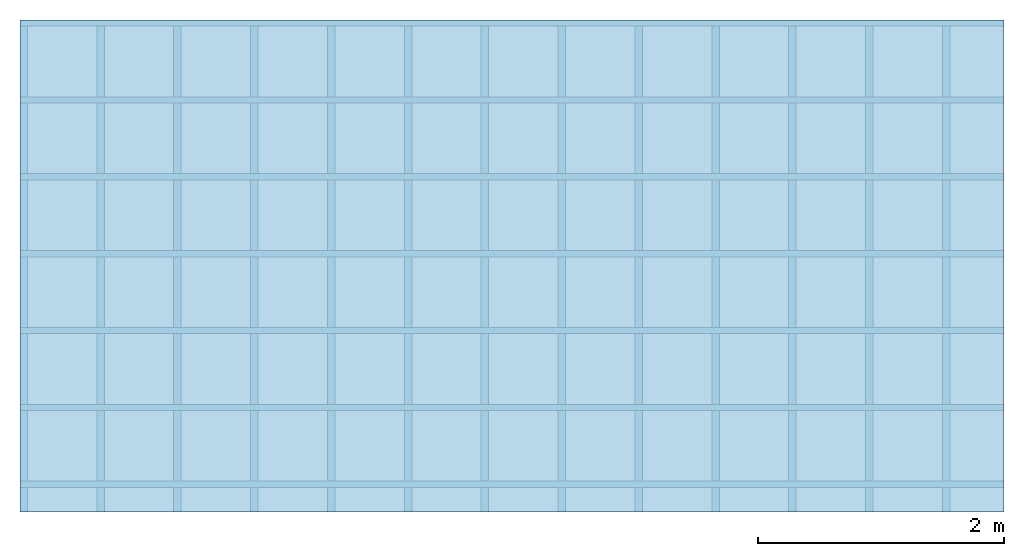
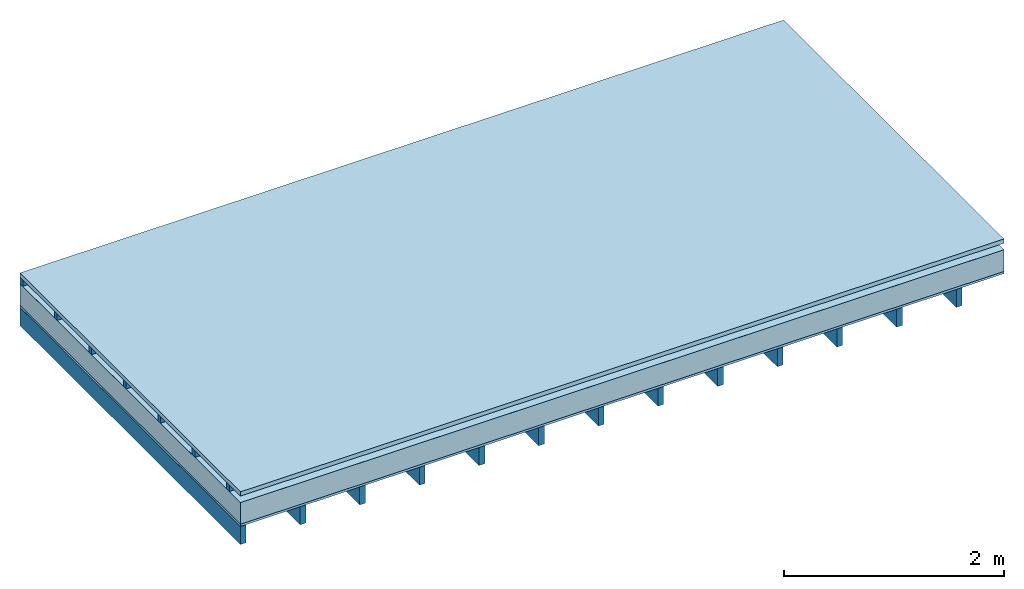
# One storey: 4 plates, 2 members, 1 element without a shape of its own.
"""IFC4 building model written with IfcOpenShell, lengths in metres."""

from ifc_helpers import new_model, si_unit, derived_unit, direction, frame, frame_2d, origin, origin_with_axes, place, context, project, spatial, rectangle, extrude, material, layer, layer_set, type_object, element, aggregate, save


model = new_model("IFC4")

# Units and contexts
plan_context = context("Plan", 3, precision=1e-05, world=origin(), true_north=direction((0.0, 1.0)))
model_context = context("Model", 3, precision=1e-05, world=origin(), true_north=direction((0.0, 1.0)))
ifc_project = project(units=[si_unit("LENGTHUNIT", "METRE"), derived_unit("SOUNDPRESSUREUNIT", [(si_unit("PRESSUREUNIT", "PASCAL", prefix="MICRO"), 0)]), si_unit("ENERGYUNIT", "JOULE", prefix="MEGA"), si_unit("MASSUNIT", "GRAM", prefix="KILO"), derived_unit("THERMALTRANSMITTANCEUNIT", [(si_unit("POWERUNIT", "WATT"), 1), (si_unit("AREAUNIT", "SQUARE_METRE"), -1), (si_unit("THERMODYNAMICTEMPERATUREUNIT", "KELVIN"), -1)]), derived_unit("AREADENSITYUNIT", [(si_unit("MASSUNIT", "GRAM", prefix="KILO"), 1), (si_unit("AREAUNIT", "SQUARE_METRE"), -1)]), derived_unit("USERDEFINED", [(si_unit("ENERGYUNIT", "JOULE", prefix="MEGA"), 1), (si_unit("AREAUNIT", "SQUARE_METRE"), -1)])], contexts=[plan_context, model_context])

# Site, building, storey
site = spatial("IfcSite", under=ifc_project)
building_placement = place(None, origin())
building = spatial("IfcBuilding", under=site, at=building_placement)
storey_placement = place(building_placement, origin())
storey = spatial("IfcBuildingStorey", under=building, at=storey_placement)

# Slab, members, plates
ifc_material_1 = material(Name="Roof tiles", Category="03.015")
ifc_layer_1 = layer(ifc_material_1, 0.047, Name="Roofing")
ifc_layer_2 = layer(None, 0.072, Name="Battens / profiles")
ifc_material_2 = material(Name="Roofing underlay", Category="09.008")
ifc_layer_3 = layer(ifc_material_2, 0.00018, Name="Under the roof")
ifc_material_3 = material(Category="10.009")
ifc_layer_4 = layer(ifc_material_3, 0.24, Name="Exterior insulation layer 1")
ifc_material_4 = material(Category="07.001")
ifc_layer_5 = layer(ifc_material_4, 0.025, Name="Sub-floor")
ifc_material_5 = material(Name="of the art")
ifc_layer_6 = layer(ifc_material_5, 0.0, Name="Bond")
ifc_layer_7 = layer(None, 0.2, Name="Supporting structure")
ifc_layer_set = layer_set([ifc_layer_1, ifc_layer_2, ifc_layer_3, ifc_layer_4, ifc_layer_5, ifc_layer_6, ifc_layer_7])
slab_type = type_object("IfcSlabType", Name="E0057", PredefinedType="NOTDEFINED", material=ifc_layer_set)
slab_placement = place(None, frame((0.0, 0.0, 0.0), z_axis=(0.0, 0.0, -1.0), x_axis=(1.0, 0.0, 0.0)))
slab = element("IfcSlab", 1, at=slab_placement, inside=storey, type_object=slab_type, material=ifc_layer_set, Name="Slab #1")
ifc_material_6 = material()
member_1_placement = place(slab_placement, origin())
member_1 = element("IfcMember", 2, at=member_1_placement, material=ifc_material_6, Name="Battens / profiles", context=plan_context, shape_type="SweptSolid", body=[
    extrude(rectangle(XDim=0.05, YDim=0.072, at=frame_2d((0.025, 0.036), x_axis=(1.0, 0.0))), frame((0.0, 0.0, 0.047), z_axis=(1.0, 0.0, 0.0), x_axis=(0.0, 1.0, 0.0)), (0.0, 0.0, 1.0), 8.0),
    extrude(rectangle(XDim=0.05, YDim=0.072, at=frame_2d((0.025, 0.036), x_axis=(1.0, 0.0))), frame((0.0, 0.625, 0.047), z_axis=(1.0, 0.0, 0.0), x_axis=(0.0, 1.0, 0.0)), (0.0, 0.0, 1.0), 8.0),
    extrude(rectangle(XDim=0.05, YDim=0.072, at=frame_2d((0.025, 0.036), x_axis=(1.0, 0.0))), frame((0.0, 1.25, 0.047), z_axis=(1.0, 0.0, 0.0), x_axis=(0.0, 1.0, 0.0)), (0.0, 0.0, 1.0), 8.0),
    extrude(rectangle(XDim=0.05, YDim=0.072, at=frame_2d((0.025, 0.036), x_axis=(1.0, 0.0))), frame((0.0, 1.875, 0.047), z_axis=(1.0, 0.0, 0.0), x_axis=(0.0, 1.0, 0.0)), (0.0, 0.0, 1.0), 8.0),
    extrude(rectangle(XDim=0.05, YDim=0.072, at=frame_2d((0.025, 0.036), x_axis=(1.0, 0.0))), frame((0.0, 2.5, 0.047), z_axis=(1.0, 0.0, 0.0), x_axis=(0.0, 1.0, 0.0)), (0.0, 0.0, 1.0), 8.0),
    extrude(rectangle(XDim=0.05, YDim=0.072, at=frame_2d((0.025, 0.036), x_axis=(1.0, 0.0))), frame((0.0, 3.125, 0.047), z_axis=(1.0, 0.0, 0.0), x_axis=(0.0, 1.0, 0.0)), (0.0, 0.0, 1.0), 8.0),
    extrude(rectangle(XDim=0.05, YDim=0.072, at=frame_2d((0.025, 0.036), x_axis=(1.0, 0.0))), frame((0.0, 3.75, 0.047), z_axis=(1.0, 0.0, 0.0), x_axis=(0.0, 1.0, 0.0)), (0.0, 0.0, 1.0), 8.0),
])
ifc_material_7 = material()
member_2_placement = place(slab_placement, origin())
member_2 = element("IfcMember", 3, at=member_2_placement, material=ifc_material_7, Name="Supporting structure", context=plan_context, shape_type="SweptSolid", body=[
    extrude(rectangle(XDim=0.06, YDim=0.2, at=frame_2d((0.03, 0.1), x_axis=(1.0, 0.0))), frame((0.0, 4.0, 0.38418), z_axis=(0.0, -1.0, 0.0), x_axis=(1.0, 0.0, 0.0)), (0.0, 0.0, 1.0), 4.0),
    extrude(rectangle(XDim=0.06, YDim=0.2, at=frame_2d((0.03, 0.1), x_axis=(1.0, 0.0))), frame((0.625, 4.0, 0.38418), z_axis=(0.0, -1.0, 0.0), x_axis=(1.0, 0.0, 0.0)), (0.0, 0.0, 1.0), 4.0),
    extrude(rectangle(XDim=0.06, YDim=0.2, at=frame_2d((0.03, 0.1), x_axis=(1.0, 0.0))), frame((1.25, 4.0, 0.38418), z_axis=(0.0, -1.0, 0.0), x_axis=(1.0, 0.0, 0.0)), (0.0, 0.0, 1.0), 4.0),
    extrude(rectangle(XDim=0.06, YDim=0.2, at=frame_2d((0.03, 0.1), x_axis=(1.0, 0.0))), frame((1.875, 4.0, 0.38418), z_axis=(0.0, -1.0, 0.0), x_axis=(1.0, 0.0, 0.0)), (0.0, 0.0, 1.0), 4.0),
    extrude(rectangle(XDim=0.06, YDim=0.2, at=frame_2d((0.03, 0.1), x_axis=(1.0, 0.0))), frame((2.5, 4.0, 0.38418), z_axis=(0.0, -1.0, 0.0), x_axis=(1.0, 0.0, 0.0)), (0.0, 0.0, 1.0), 4.0),
    extrude(rectangle(XDim=0.06, YDim=0.2, at=frame_2d((0.03, 0.1), x_axis=(1.0, 0.0))), frame((3.125, 4.0, 0.38418), z_axis=(0.0, -1.0, 0.0), x_axis=(1.0, 0.0, 0.0)), (0.0, 0.0, 1.0), 4.0),
    extrude(rectangle(XDim=0.06, YDim=0.2, at=frame_2d((0.03, 0.1), x_axis=(1.0, 0.0))), frame((3.75, 4.0, 0.38418), z_axis=(0.0, -1.0, 0.0), x_axis=(1.0, 0.0, 0.0)), (0.0, 0.0, 1.0), 4.0),
    extrude(rectangle(XDim=0.06, YDim=0.2, at=frame_2d((0.03, 0.1), x_axis=(1.0, 0.0))), frame((4.375, 4.0, 0.38418), z_axis=(0.0, -1.0, 0.0), x_axis=(1.0, 0.0, 0.0)), (0.0, 0.0, 1.0), 4.0),
    extrude(rectangle(XDim=0.06, YDim=0.2, at=frame_2d((0.03, 0.1), x_axis=(1.0, 0.0))), frame((5.0, 4.0, 0.38418), z_axis=(0.0, -1.0, 0.0), x_axis=(1.0, 0.0, 0.0)), (0.0, 0.0, 1.0), 4.0),
    extrude(rectangle(XDim=0.06, YDim=0.2, at=frame_2d((0.03, 0.1), x_axis=(1.0, 0.0))), frame((5.625, 4.0, 0.38418), z_axis=(0.0, -1.0, 0.0), x_axis=(1.0, 0.0, 0.0)), (0.0, 0.0, 1.0), 4.0),
    extrude(rectangle(XDim=0.06, YDim=0.2, at=frame_2d((0.03, 0.1), x_axis=(1.0, 0.0))), frame((6.25, 4.0, 0.38418), z_axis=(0.0, -1.0, 0.0), x_axis=(1.0, 0.0, 0.0)), (0.0, 0.0, 1.0), 4.0),
    extrude(rectangle(XDim=0.06, YDim=0.2, at=frame_2d((0.03, 0.1), x_axis=(1.0, 0.0))), frame((6.875, 4.0, 0.38418), z_axis=(0.0, -1.0, 0.0), x_axis=(1.0, 0.0, 0.0)), (0.0, 0.0, 1.0), 4.0),
    extrude(rectangle(XDim=0.06, YDim=0.2, at=frame_2d((0.03, 0.1), x_axis=(1.0, 0.0))), frame((7.5, 4.0, 0.38418), z_axis=(0.0, -1.0, 0.0), x_axis=(1.0, 0.0, 0.0)), (0.0, 0.0, 1.0), 4.0),
])
plate_1_placement = place(slab_placement, origin())
plate_1 = element("IfcPlate", 4, at=plate_1_placement, material=ifc_material_1, Name="Roofing", context=plan_context, shape_type="SweptSolid", body=[
    extrude(rectangle(XDim=8.0, YDim=4.0, at=frame_2d((4.0, 2.0), x_axis=(1.0, 0.0))), origin_with_axes(), (0.0, 0.0, 1.0), 0.047),
])
plate_2_placement = place(slab_placement, origin())
plate_2 = element("IfcPlate", 5, at=plate_2_placement, material=ifc_material_2, Name="Under the roof", context=plan_context, shape_type="SweptSolid", body=[
    extrude(rectangle(XDim=8.0, YDim=4.0, at=frame_2d((4.0, 2.0), x_axis=(1.0, 0.0))), frame((0.0, 0.0, 0.119), z_axis=(0.0, 0.0, 1.0), x_axis=(1.0, 0.0, 0.0)), (0.0, 0.0, 1.0), 0.00018),
])
plate_3_placement = place(slab_placement, origin())
plate_3 = element("IfcPlate", 6, at=plate_3_placement, material=ifc_material_3, Name="Exterior insulation layer 1", context=plan_context, shape_type="SweptSolid", body=[
    extrude(rectangle(XDim=8.0, YDim=4.0, at=frame_2d((4.0, 2.0), x_axis=(1.0, 0.0))), frame((0.0, 0.0, 0.11918), z_axis=(0.0, 0.0, 1.0), x_axis=(1.0, 0.0, 0.0)), (0.0, 0.0, 1.0), 0.24),
])
plate_4_placement = place(slab_placement, origin())
plate_4 = element("IfcPlate", 7, at=plate_4_placement, material=ifc_material_4, Name="Sub-floor", context=plan_context, shape_type="SweptSolid", body=[
    extrude(rectangle(XDim=8.0, YDim=4.0, at=frame_2d((4.0, 2.0), x_axis=(1.0, 0.0))), frame((0.0, 0.0, 0.35918), z_axis=(0.0, 0.0, 1.0), x_axis=(1.0, 0.0, 0.0)), (0.0, 0.0, 1.0), 0.025),
])
aggregate(slab, [plate_1, member_1, plate_2, plate_3, plate_4, member_2])

save(model, "model.ifc")
